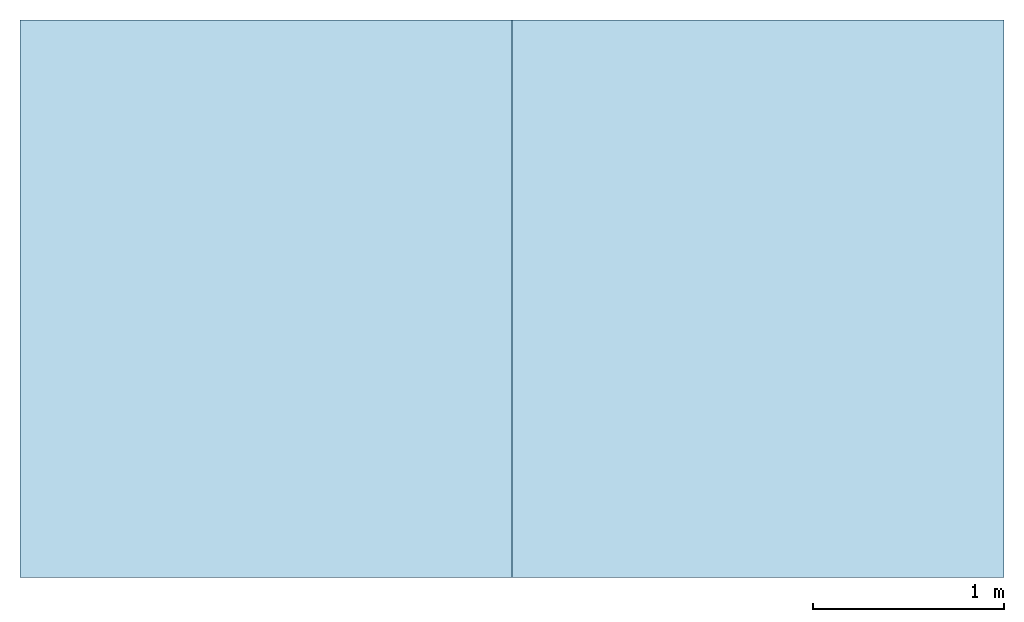
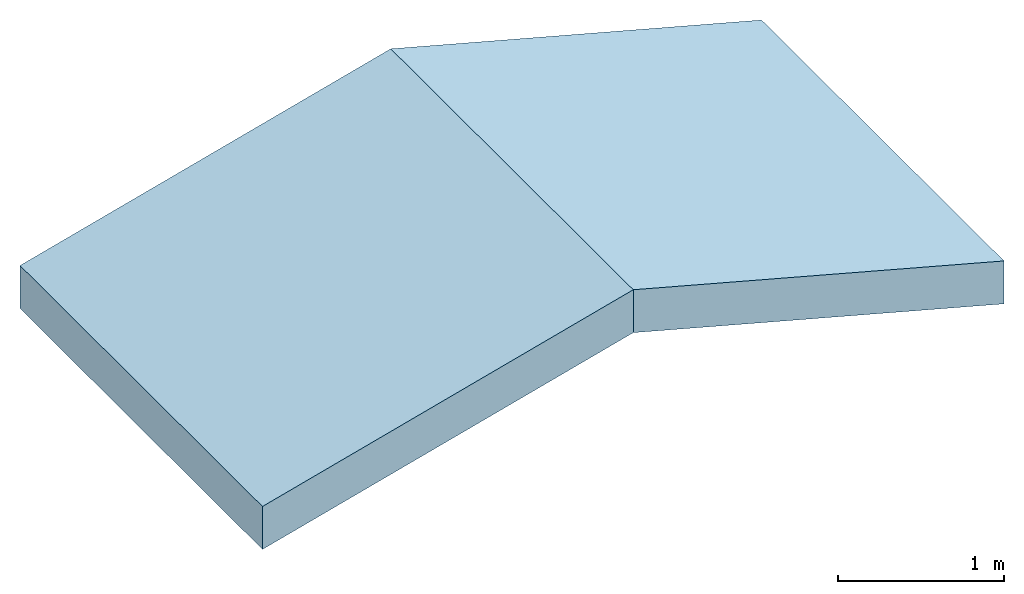
# One storey: 2 slabs, 1 element without a shape of its own.
"""IFC4 building model written with IfcOpenShell, lengths in feet."""

from ifc_helpers import new_model, entity, si_unit, converted_unit, derived_unit, direction, frame, frame_2d, origin, origin_2d_with_axis, place, context, subcontext, project, spatial, rectangle, extrude, material, layer, layer_set, type_object, element, aggregate, save


model = new_model("IFC4")

# Units and contexts
model_context = context("Model", 3, precision=0.0001, world=origin(), true_north=direction((6.12303176911189e-17, 1.0)))
body_context = subcontext(model_context, "Body", "Model", "MODEL_VIEW")
ifc_project = project(units=[converted_unit("LENGTHUNIT", "FOOT", entity("IfcRatioMeasure", 0.3048), si_unit("LENGTHUNIT", "METRE"), dimensions=[1, 0, 0, 0, 0, 0, 0]), converted_unit("AREAUNIT", "SQUARE FOOT", entity("IfcRatioMeasure", 0.09290304), si_unit("AREAUNIT", "SQUARE_METRE"), dimensions=[2, 0, 0, 0, 0, 0, 0]), converted_unit("VOLUMEUNIT", "CUBIC FOOT", entity("IfcRatioMeasure", 0.028316846592), si_unit("VOLUMEUNIT", "CUBIC_METRE"), dimensions=[3, 0, 0, 0, 0, 0, 0]), converted_unit("PLANEANGLEUNIT", "DEGREE", entity("IfcRatioMeasure", 0.0174532925199433), si_unit("PLANEANGLEUNIT", "RADIAN"), dimensions=[0, 0, 0, 0, 0, 0, 0]), si_unit("MASSUNIT", "GRAM", prefix="KILO"), derived_unit("MASSDENSITYUNIT", [(si_unit("MASSUNIT", "GRAM", prefix="KILO"), 1), (si_unit("LENGTHUNIT", "METRE"), -3)]), derived_unit("MOMENTOFINERTIAUNIT", [(si_unit("LENGTHUNIT", "METRE"), 4)]), si_unit("TIMEUNIT", "SECOND"), si_unit("FREQUENCYUNIT", "HERTZ"), si_unit("THERMODYNAMICTEMPERATUREUNIT", "DEGREE_CELSIUS"), derived_unit("THERMALTRANSMITTANCEUNIT", [(si_unit("MASSUNIT", "GRAM", prefix="KILO"), 1), (si_unit("THERMODYNAMICTEMPERATUREUNIT", "KELVIN"), -1), (si_unit("TIMEUNIT", "SECOND"), -3)]), derived_unit("VOLUMETRICFLOWRATEUNIT", [(si_unit("LENGTHUNIT", "METRE"), 3), (si_unit("TIMEUNIT", "SECOND"), -1)]), si_unit("ELECTRICCURRENTUNIT", "AMPERE"), si_unit("ELECTRICVOLTAGEUNIT", "VOLT"), si_unit("POWERUNIT", "WATT"), si_unit("FORCEUNIT", "NEWTON"), si_unit("ILLUMINANCEUNIT", "LUX"), si_unit("LUMINOUSFLUXUNIT", "LUMEN"), si_unit("LUMINOUSINTENSITYUNIT", "CANDELA"), derived_unit("USERDEFINED", [(si_unit("MASSUNIT", "GRAM", prefix="KILO"), -1), (si_unit("LENGTHUNIT", "METRE"), -2), (si_unit("TIMEUNIT", "SECOND"), 3), (si_unit("LUMINOUSFLUXUNIT", "LUMEN"), 1)]), derived_unit("LINEARVELOCITYUNIT", [(si_unit("LENGTHUNIT", "METRE"), 1), (si_unit("TIMEUNIT", "SECOND"), -1)]), si_unit("PRESSUREUNIT", "PASCAL"), derived_unit("USERDEFINED", [(si_unit("LENGTHUNIT", "METRE"), -2), (si_unit("MASSUNIT", "GRAM", prefix="KILO"), 1), (si_unit("TIMEUNIT", "SECOND"), -2)]), derived_unit("LINEARFORCEUNIT", [(si_unit("MASSUNIT", "GRAM", prefix="KILO"), 1), (si_unit("LENGTHUNIT", "METRE"), 1), (si_unit("TIMEUNIT", "SECOND"), -2), (si_unit("LENGTHUNIT", "METRE"), -1)]), derived_unit("PLANARFORCEUNIT", [(si_unit("MASSUNIT", "GRAM", prefix="KILO"), 1), (si_unit("LENGTHUNIT", "METRE"), 1), (si_unit("TIMEUNIT", "SECOND"), -2), (si_unit("LENGTHUNIT", "METRE"), -2)])], contexts=[model_context])

# Site, building, storey
site_placement = place(None, origin())
site = spatial("IfcSite", under=ifc_project, at=site_placement, CompositionType="ELEMENT")
building_placement = place(site_placement, origin())
building = spatial("IfcBuilding", under=site, at=building_placement, CompositionType="ELEMENT")
storey_placement = place(building_placement, frame((0.0, 0.0, 10.0)))
storey = spatial("IfcBuildingStorey", under=building, at=storey_placement, Name="Level 2", CompositionType="ELEMENT", Elevation=10.0)

# Roof, slabs
roof_placement = place(storey_placement, frame((-3.8206898845645, -4.31944009904624, 1.5)))
roof = element("IfcRoof", 1, at=roof_placement, inside=storey, PredefinedType="NOTDEFINED")
ifc_material = material(Name="Default Roof", Category="Materials")
ifc_layer = layer(ifc_material, 1.0, Name="Layer", Category="Materials")
ifc_layer_set = layer_set([ifc_layer])
slab_type_1 = type_object("IfcSlabType", PredefinedType="ROOF")
slab_1_placement = place(roof_placement, origin())
slab_1 = element("IfcSlab", 2, at=slab_1_placement, type_object=slab_type_1, material=ifc_layer_set, PredefinedType="ROOF", context=body_context, shape_type="SweptSolid", body=[
    extrude(rectangle(XDim=9.58333333333333, YDim=8.75671102596862, at=frame_2d((-8.88178419700125e-16, 0.0), x_axis=(0.0, 1.0))), frame((4.22916666666667, 4.79166666666667, 1.13320179298995), z_axis=(-0.25881904510252, 0.0, 0.965925826289069), x_axis=(0.965925826289069, 0.0, 0.25881904510252)), (0.25881904510252, 0.0, 0.965925826289069), 1.03527618041008),
])
slab_type_2 = type_object("IfcSlabType", PredefinedType="ROOF")
slab_2_placement = place(roof_placement, origin())
slab_2 = element("IfcSlab", 3, at=slab_2_placement, type_object=slab_type_2, material=ifc_layer_set, PredefinedType="ROOF", context=body_context, shape_type="SweptSolid", body=[
    extrude(rectangle(XDim=8.75671102596862, YDim=9.58333333333333, at=origin_2d_with_axis()), frame((12.6875, 4.79166666666667, 1.13320179298995), z_axis=(0.25881904510252, 0.0, 0.965925826289069), x_axis=(0.965925826289069, 0.0, -0.25881904510252)), (-0.25881904510252, 0.0, 0.965925826289069), 1.03527618041008),
])
aggregate(roof, [slab_1, slab_2])

save(model, "model.ifc")
